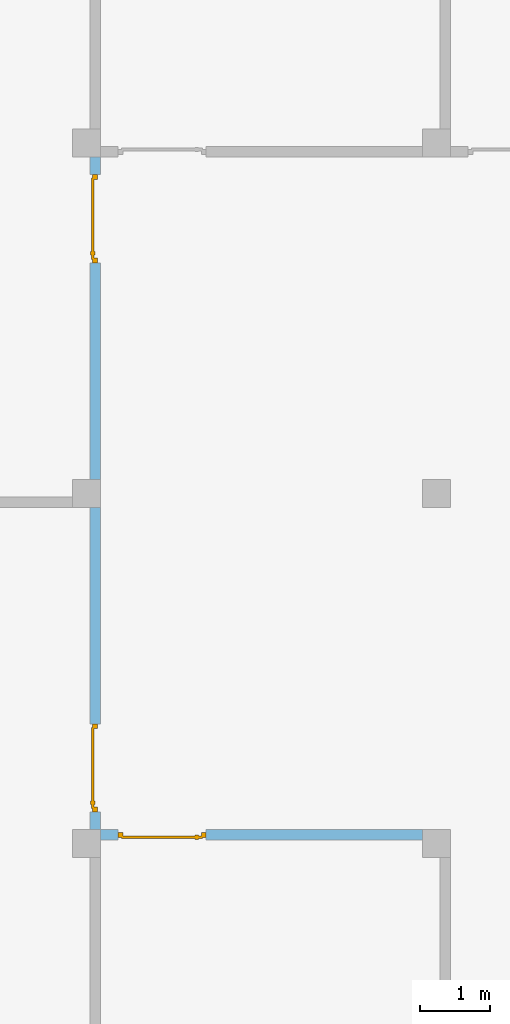
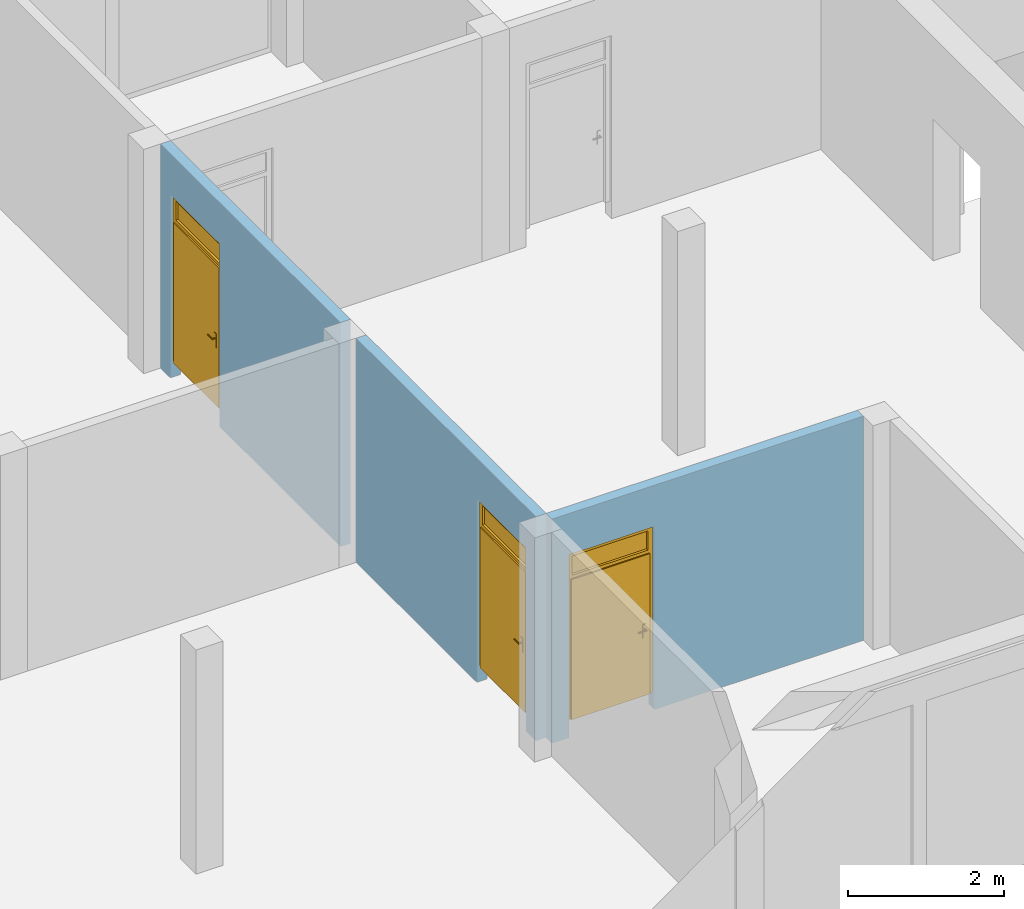
# One storey, part 2 of 6: 3 doors, 3 openings, plus 3 elements that do not belong to this part.
"""IFC2X3 building model written with IfcOpenShell, lengths in metres."""

from ifc_helpers import new_model, entity, si_unit, converted_unit, frame, frame_2d, origin, origin_with_axes, place, context, subcontext, project, spatial, polyline, rectangle, outline, extrude, closed_shell, open_shell, surface_model, source, transform, mapped, material, layer, layer_set, layer_usage, type_object, element, fill, save


model = new_model("IFC2X3")

# Units and contexts
model_context = context("Model", 3, precision=1e-05, world=origin())
body_context = subcontext(model_context, "Body", "Model", "MODEL_VIEW")
ifc_project = project(units=[si_unit("LENGTHUNIT", "METRE"), si_unit("AREAUNIT", "SQUARE_METRE"), si_unit("VOLUMEUNIT", "CUBIC_METRE"), si_unit("MASSUNIT", "GRAM", prefix="KILO"), converted_unit("PLANEANGLEUNIT", "DEGREE", entity("IfcPlaneAngleMeasure", 0.0174532925199433), si_unit("PLANEANGLEUNIT", "RADIAN"), dimensions=[0, 0, 0, 0, 0, 0, 0])], contexts=[model_context])

# Site, building, storey
site_placement = place(None, origin())
site = spatial("IfcSite", under=ifc_project, at=site_placement, CompositionType="ELEMENT")
building_placement = place(site_placement, origin())
building = spatial("IfcBuilding", under=site, at=building_placement, CompositionType="ELEMENT")
storey_placement = place(building_placement, frame((0.0, 0.0, 8.6)))
storey = spatial("IfcBuildingStorey", under=building, at=storey_placement, Name="2. Obergeschoss", CompositionType="ELEMENT", Elevation=8.6)

# Wall, opening, door
ifc_material_1 = material()
ifc_layer_1 = layer(ifc_material_1, 0.15)
ifc_layer_set_1 = layer_set([ifc_layer_1])
ifc_layer_usage_1 = layer_usage(ifc_layer_set_1, "AXIS2", "POSITIVE", -0.15)
wall_1_placement = place(storey_placement, frame((10.4, 5.25, 0.0)))
wall_1 = element("IfcWallStandardCase", 1, at=wall_1_placement, inside=storey, material=ifc_layer_usage_1, context=body_context, shape_type="SweptSolid", body=[
    extrude(rectangle(XDim=4.6, YDim=0.15, at=frame_2d((2.3, 0.075), x_axis=(1.0, 0.0))), origin_with_axes(), (0.0, 0.0, 1.0), 3.5),
])
opening_1_placement = place(wall_1_placement, frame((1.51, 0.15, 0.0), z_axis=(0.0, -1.0, 0.0), x_axis=(0.0, 0.0, 1.0)))
opening_1 = element("IfcOpeningElement", 2, at=opening_1_placement, cuts=wall_1, ObjectType="Opening", context=body_context, shape_type="SweptSolid", body=[
    extrude(outline(polyline([(0.0, 1.26), (2.86, 1.26), (2.86, 0.0), (0.0, 0.0), (0.0, 1.26)])), origin_with_axes(), (0.0, 0.0, 1.0), 0.15),
])
ifc_material_2 = material()
door_style_1 = type_object("IfcDoorStyle", ConstructionType="NOTDEFINED", OperationType="SINGLE_SWING_RIGHT", ParameterTakesPrecedence=False, Sizeable=False)
shared_shape_1 = source(origin_with_axes(), body_context, "Body", "SurfaceModel", [
    surface_model("IfcShellBasedSurfaceModel", [(0.0, 0.0700000000000009, 2.86), (0.0, 0.07, 0.25), (0.07, 0.07, 0.25), (0.07, 0.0700000000000009, 2.86), (0.0, 0.0, 0.25), (0.0, 0.0, 2.86), (0.07, 0.0, 2.86), (0.07, 0.0, 0.25)], [closed_shell([[[0, 1, 2, 3]], [[4, 5, 6, 7]], [[1, 0, 5, 4]], [[2, 1, 4, 7]], [[3, 2, 7, 6]], [[0, 3, 6, 5]]], orient=[[False], [False], [False], [False], [False], [False]])]),
    surface_model("IfcShellBasedSurfaceModel", [(1.19, 0.0700000000000009, 2.86), (1.19, 0.07, 0.25), (1.26, 0.07, 0.25), (1.26, 0.0700000000000009, 2.86), (1.19, 0.0, 0.25), (1.19, 0.0, 2.86), (1.26, 0.0, 2.86), (1.26, 0.0, 0.25)], [closed_shell([[[0, 1, 2, 3]], [[4, 5, 6, 7]], [[1, 0, 5, 4]], [[2, 1, 4, 7]], [[3, 2, 7, 6]], [[0, 3, 6, 5]]], orient=[[False], [False], [False], [False], [False], [False]])]),
    surface_model("IfcShellBasedSurfaceModel", [(0.07, 0.0700000000000009, 2.86), (0.07, 0.0700000000000009, 2.79), (1.19, 0.0700000000000009, 2.79), (1.19, 0.0700000000000009, 2.86), (0.07, 0.0, 2.79), (0.07, 0.0, 2.86), (1.19, 0.0, 2.86), (1.19, 0.0, 2.79)], [closed_shell([[[0, 1, 2, 3]], [[4, 5, 6, 7]], [[1, 0, 5, 4]], [[2, 1, 4, 7]], [[3, 2, 7, 6]], [[0, 3, 6, 5]]], orient=[[False], [False], [False], [False], [False], [False]])]),
    surface_model("IfcShellBasedSurfaceModel", [(0.07, 0.0700000000000009, 2.49), (0.07, 0.0700000000000009, 2.42), (1.19, 0.0700000000000009, 2.42), (1.19, 0.0700000000000009, 2.49), (0.07, 0.0, 2.42), (0.07, 0.0, 2.49), (1.19, 0.0, 2.49), (1.19, 0.0, 2.42)], [closed_shell([[[0, 1, 2, 3]], [[4, 5, 6, 7]], [[1, 0, 5, 4]], [[2, 1, 4, 7]], [[3, 2, 7, 6]], [[0, 3, 6, 5]]], orient=[[False], [False], [False], [False], [False], [False]])]),
    surface_model("IfcShellBasedSurfaceModel", [(0.05, 0.0900000000000009, 2.44), (0.05, 0.0900000000000009, 0.25), (1.21, 0.09, 0.25), (1.21, 0.0900000000000009, 2.44), (0.05, 0.05, 0.25), (0.05, 0.0500000000000009, 2.44), (1.21, 0.05, 2.44), (1.21, 0.05, 0.25)], [closed_shell([[[0, 1, 2, 3]], [[4, 5, 6, 7]], [[1, 0, 5, 4]], [[2, 1, 4, 7]], [[3, 2, 7, 6]], [[0, 3, 6, 5]]], orient=[[False], [False], [False], [False], [False], [False]])]),
    surface_model("IfcShellBasedSurfaceModel", [(0.11, 0.05, 1.375), (0.11, 0.05, 1.16), (0.16, 0.05, 1.16), (0.16, 0.05, 1.375), (0.11, 0.04, 1.16), (0.11, 0.04, 1.375), (0.16, 0.04, 1.375), (0.16, 0.04, 1.16)], [closed_shell([[[0, 1, 2, 3]], [[4, 5, 6, 7]], [[1, 0, 5, 4]], [[2, 1, 4, 7]], [[3, 2, 7, 6]], [[0, 3, 6, 5]]], orient=[[False], [False], [False], [False], [False], [False]])]),
    surface_model("IfcShellBasedSurfaceModel", [(0.135, 0.04, 1.31), (0.13, 0.04, 1.30866025403784), (0.126339745962156, 0.04, 1.305), (0.125, 0.04, 1.3), (0.126339745962156, 0.04, 1.295), (0.13, 0.04, 1.29133974596216), (0.135, 0.04, 1.29), (0.14, 0.04, 1.29133974596216), (0.143660254037844, 0.04, 1.295), (0.145, 0.04, 1.3), (0.143660254037844, 0.04, 1.305), (0.14, 0.04, 1.30866025403784), (0.135, 0.0, 1.31), (0.13, -0.005, 1.30866025403784), (0.126339745962156, -0.00866025403784442, 1.305), (0.125, -0.01, 1.3), (0.126339745962156, -0.00866025403784442, 1.295), (0.13, -0.005, 1.29133974596216), (0.135, 0.0, 1.29), (0.14, 0.005, 1.29133974596216), (0.143660254037844, 0.00866025403784442, 1.295), (0.145, 0.01, 1.3), (0.143660254037844, 0.00866025403784442, 1.305), (0.14, 0.005, 1.30866025403784), (0.25, 0.0, 1.31), (0.25, 0.005, 1.30866025403784), (0.25, 0.00866025403784442, 1.305), (0.25, 0.01, 1.3), (0.25, 0.00866025403784442, 1.295), (0.25, 0.005, 1.29133974596216), (0.25, 0.0, 1.29), (0.25, -0.005, 1.29133974596216), (0.25, -0.00866025403784442, 1.295), (0.25, -0.01, 1.3), (0.25, -0.00866025403784442, 1.305), (0.25, -0.005, 1.30866025403784)], [closed_shell([[[0, 1, 2, 3, 4, 5, 6, 7, 8, 9, 10, 11]], [[0, 12, 13, 1]], [[1, 13, 14, 2]], [[2, 14, 15, 3]], [[3, 15, 16, 4]], [[4, 16, 17, 5]], [[5, 17, 18, 6]], [[6, 18, 19, 7]], [[7, 19, 20, 8]], [[8, 20, 21, 9]], [[9, 21, 22, 10]], [[10, 22, 23, 11]], [[11, 23, 12, 0]], [[24, 25, 26, 27, 28, 29, 30, 31, 32, 33, 34, 35]], [[12, 24, 35, 13]], [[13, 35, 34, 14]], [[14, 34, 33, 15]], [[15, 33, 32, 16]], [[16, 32, 31, 17]], [[17, 31, 30, 18]], [[18, 30, 29, 19]], [[19, 29, 28, 20]], [[20, 28, 27, 21]], [[21, 27, 26, 22]], [[22, 26, 25, 23]], [[23, 25, 24, 12]]], orient=[[False], [False], [False], [False], [False], [False], [False], [False], [False], [False], [False], [False], [False], [False], [False], [False], [False], [False], [False], [False], [False], [False], [False], [False], [False], [False]])]),
    surface_model("IfcShellBasedSurfaceModel", [(0.11, 0.0900000000000009, 1.375), (0.16, 0.0900000000000009, 1.375), (0.16, 0.0900000000000009, 1.16), (0.11, 0.0900000000000009, 1.16), (0.11, 0.100000000000001, 1.16), (0.16, 0.100000000000001, 1.16), (0.16, 0.100000000000001, 1.375), (0.11, 0.100000000000001, 1.375)], [closed_shell([[[0, 1, 2, 3]], [[4, 5, 6, 7]], [[3, 4, 7, 0]], [[2, 5, 4, 3]], [[1, 6, 5, 2]], [[0, 7, 6, 1]]], orient=[[False], [False], [False], [False], [False], [False]])]),
    surface_model("IfcShellBasedSurfaceModel", [(0.135, 0.100000000000001, 1.31), (0.14, 0.100000000000001, 1.30866025403784), (0.143660254037844, 0.100000000000001, 1.305), (0.145, 0.100000000000001, 1.3), (0.143660254037844, 0.100000000000001, 1.295), (0.14, 0.100000000000001, 1.29133974596216), (0.135, 0.100000000000001, 1.29), (0.13, 0.100000000000001, 1.29133974596216), (0.126339745962156, 0.100000000000001, 1.295), (0.125, 0.100000000000001, 1.3), (0.126339745962156, 0.100000000000001, 1.305), (0.13, 0.100000000000001, 1.30866025403784), (0.13, 0.145000000000001, 1.30866025403784), (0.135, 0.140000000000001, 1.31), (0.126339745962156, 0.148660254037845, 1.305), (0.125, 0.150000000000001, 1.3), (0.126339745962156, 0.148660254037845, 1.295), (0.13, 0.145000000000001, 1.29133974596216), (0.135, 0.140000000000001, 1.29), (0.14, 0.135000000000001, 1.29133974596216), (0.143660254037844, 0.131339745962157, 1.295), (0.145, 0.130000000000001, 1.3), (0.143660254037844, 0.131339745962157, 1.305), (0.14, 0.135000000000001, 1.30866025403784), (0.25, 0.140000000000001, 1.31), (0.25, 0.145000000000001, 1.30866025403784), (0.25, 0.148660254037845, 1.305), (0.25, 0.150000000000001, 1.3), (0.25, 0.148660254037845, 1.295), (0.25, 0.145000000000001, 1.29133974596216), (0.25, 0.140000000000001, 1.29), (0.25, 0.135000000000001, 1.29133974596216), (0.25, 0.131339745962157, 1.295), (0.25, 0.130000000000001, 1.3), (0.25, 0.131339745962157, 1.305), (0.25, 0.135000000000001, 1.30866025403784)], [closed_shell([[[0, 1, 2, 3, 4, 5, 6, 7, 8, 9, 10, 11]], [[0, 11, 12, 13]], [[11, 10, 14, 12]], [[10, 9, 15, 14]], [[9, 8, 16, 15]], [[8, 7, 17, 16]], [[7, 6, 18, 17]], [[6, 5, 19, 18]], [[5, 4, 20, 19]], [[4, 3, 21, 20]], [[3, 2, 22, 21]], [[2, 1, 23, 22]], [[1, 0, 13, 23]], [[24, 25, 26, 27, 28, 29, 30, 31, 32, 33, 34, 35]], [[13, 12, 25, 24]], [[12, 14, 26, 25]], [[14, 15, 27, 26]], [[15, 16, 28, 27]], [[16, 17, 29, 28]], [[17, 18, 30, 29]], [[18, 19, 31, 30]], [[19, 20, 32, 31]], [[20, 21, 33, 32]], [[21, 22, 34, 33]], [[22, 23, 35, 34]], [[23, 13, 24, 35]]], orient=[[False], [False], [False], [False], [False], [False], [False], [False], [False], [False], [False], [False], [False], [False], [False], [False], [False], [False], [False], [False], [False], [False], [False], [False], [False], [False]])]),
    surface_model("IfcShellBasedSurfaceModel", [(0.07, 0.0350000000000009, 2.49), (1.19, 0.035, 2.49), (1.19, 0.035, 2.79), (0.07, 0.0350000000000009, 2.79)], [open_shell([[[0, 1, 2, 3]]], orient=[[False]])]),
])
door_1_placement = place(opening_1_placement, frame((0.0, 0.0, 0.04), z_axis=(1.0, 0.0, 0.0), x_axis=(0.0, 1.0, 0.0)))
door_1 = element("IfcDoor", 3, at=door_1_placement, inside=storey, type_object=door_style_1, material=ifc_material_2, OverallHeight=2.86, OverallWidth=1.26, context=body_context, shape_type="MappedRepresentation", body=[
    mapped(shared_shape_1, transform((0.0, 0.0, 0.0), x_axis=(1.0, 0.0, 0.0), y_axis=(0.0, 1.0, 0.0), z_axis=(0.0, 0.0, 1.0), scale=1.0)),
])
fill(opening_1, door_1)

ifc_material_3 = material()
ifc_layer_2 = layer(ifc_material_3, 0.15)
ifc_layer_set_2 = layer_set([ifc_layer_2])
ifc_layer_usage_2 = layer_usage(ifc_layer_set_2, "AXIS2", "POSITIVE", -0.15)
wall_2_placement = place(storey_placement, frame((10.25, 10.0, 0.0), z_axis=(0.0, 0.0, 1.0), x_axis=(0.0, -1.0, 0.0)))
wall_2 = element("IfcWallStandardCase", 4, at=wall_2_placement, inside=storey, material=ifc_layer_usage_2, context=body_context, shape_type="SweptSolid", body=[
    extrude(rectangle(XDim=4.6, YDim=0.15, at=frame_2d((2.3, 0.075), x_axis=(1.0, 0.0))), origin_with_axes(), (0.0, 0.0, 1.0), 3.5),
])
opening_2_placement = place(wall_2_placement, frame((4.35, 0.15, 0.0), z_axis=(0.0, -1.0, 0.0), x_axis=(0.0, 0.0, 1.0)))
opening_2 = element("IfcOpeningElement", 5, at=opening_2_placement, cuts=wall_2, ObjectType="Opening", context=body_context, shape_type="SweptSolid", body=[
    extrude(outline(polyline([(0.0, 1.26), (2.86, 1.26), (2.86, 0.0), (0.0, 0.0), (0.0, 1.26)])), origin_with_axes(), (0.0, 0.0, 1.0), 0.15),
])
ifc_material_4 = material()
door_style_2 = type_object("IfcDoorStyle", ConstructionType="NOTDEFINED", OperationType="SINGLE_SWING_RIGHT", ParameterTakesPrecedence=False, Sizeable=False)
shared_shape_2 = source(origin_with_axes(), body_context, "Body", "SurfaceModel", [
    surface_model("IfcShellBasedSurfaceModel", [(0.0, 0.07, 2.86), (0.0, 0.07, 0.25), (0.07, 0.07, 0.25), (0.07, 0.07, 2.86), (0.0, 0.0, 0.25), (0.0, 0.0, 2.86), (0.07, 0.0, 2.86), (0.07, 0.0, 0.25)], [closed_shell([[[0, 1, 2, 3]], [[4, 5, 6, 7]], [[1, 0, 5, 4]], [[2, 1, 4, 7]], [[3, 2, 7, 6]], [[0, 3, 6, 5]]], orient=[[False], [False], [False], [False], [False], [False]])]),
    surface_model("IfcShellBasedSurfaceModel", [(1.19, 0.07, 2.86), (1.19, 0.07, 0.25), (1.26, 0.07, 0.25), (1.26, 0.07, 2.86), (1.19, 0.0, 0.25), (1.19, 0.0, 2.86), (1.26, 0.0, 2.86), (1.26, 0.0, 0.25)], [closed_shell([[[0, 1, 2, 3]], [[4, 5, 6, 7]], [[1, 0, 5, 4]], [[2, 1, 4, 7]], [[3, 2, 7, 6]], [[0, 3, 6, 5]]], orient=[[False], [False], [False], [False], [False], [False]])]),
    surface_model("IfcShellBasedSurfaceModel", [(0.07, 0.07, 2.86), (0.07, 0.07, 2.79), (1.19, 0.07, 2.79), (1.19, 0.07, 2.86), (0.07, 0.0, 2.79), (0.07, 0.0, 2.86), (1.19, 0.0, 2.86), (1.19, 0.0, 2.79)], [closed_shell([[[0, 1, 2, 3]], [[4, 5, 6, 7]], [[1, 0, 5, 4]], [[2, 1, 4, 7]], [[3, 2, 7, 6]], [[0, 3, 6, 5]]], orient=[[False], [False], [False], [False], [False], [False]])]),
    surface_model("IfcShellBasedSurfaceModel", [(0.07, 0.07, 2.49), (0.07, 0.07, 2.42), (1.19, 0.07, 2.42), (1.19, 0.07, 2.49), (0.07, 0.0, 2.42), (0.07, 0.0, 2.49), (1.19, 0.0, 2.49), (1.19, 0.0, 2.42)], [closed_shell([[[0, 1, 2, 3]], [[4, 5, 6, 7]], [[1, 0, 5, 4]], [[2, 1, 4, 7]], [[3, 2, 7, 6]], [[0, 3, 6, 5]]], orient=[[False], [False], [False], [False], [False], [False]])]),
    surface_model("IfcShellBasedSurfaceModel", [(0.05, 0.09, 2.44), (0.05, 0.09, 0.25), (1.21, 0.09, 0.25), (1.21, 0.09, 2.44), (0.05, 0.05, 0.25), (0.05, 0.05, 2.44), (1.21, 0.05, 2.44), (1.21, 0.05, 0.25)], [closed_shell([[[0, 1, 2, 3]], [[4, 5, 6, 7]], [[1, 0, 5, 4]], [[2, 1, 4, 7]], [[3, 2, 7, 6]], [[0, 3, 6, 5]]], orient=[[False], [False], [False], [False], [False], [False]])]),
    surface_model("IfcShellBasedSurfaceModel", [(0.11, 0.05, 1.375), (0.11, 0.05, 1.16), (0.16, 0.05, 1.16), (0.16, 0.05, 1.375), (0.11, 0.04, 1.16), (0.11, 0.04, 1.375), (0.16, 0.04, 1.375), (0.16, 0.04, 1.16)], [closed_shell([[[0, 1, 2, 3]], [[4, 5, 6, 7]], [[1, 0, 5, 4]], [[2, 1, 4, 7]], [[3, 2, 7, 6]], [[0, 3, 6, 5]]], orient=[[False], [False], [False], [False], [False], [False]])]),
    surface_model("IfcShellBasedSurfaceModel", [(0.135, 0.04, 1.31), (0.13, 0.04, 1.30866025403784), (0.126339745962156, 0.04, 1.305), (0.125, 0.04, 1.3), (0.126339745962156, 0.04, 1.295), (0.13, 0.04, 1.29133974596216), (0.135, 0.04, 1.29), (0.14, 0.04, 1.29133974596216), (0.143660254037844, 0.04, 1.295), (0.145, 0.04, 1.3), (0.143660254037844, 0.04, 1.305), (0.14, 0.04, 1.30866025403784), (0.135, 0.0, 1.31), (0.13, -0.005, 1.30866025403784), (0.126339745962156, -0.00866025403784442, 1.305), (0.125, -0.01, 1.3), (0.126339745962156, -0.00866025403784442, 1.295), (0.13, -0.005, 1.29133974596216), (0.135, 0.0, 1.29), (0.14, 0.005, 1.29133974596216), (0.143660254037844, 0.00866025403784442, 1.295), (0.145, 0.01, 1.3), (0.143660254037844, 0.00866025403784442, 1.305), (0.14, 0.005, 1.30866025403784), (0.25, 0.0, 1.31), (0.25, 0.005, 1.30866025403784), (0.25, 0.00866025403784442, 1.305), (0.25, 0.01, 1.3), (0.25, 0.00866025403784442, 1.295), (0.25, 0.005, 1.29133974596216), (0.25, 0.0, 1.29), (0.25, -0.005, 1.29133974596216), (0.25, -0.00866025403784442, 1.295), (0.25, -0.01, 1.3), (0.25, -0.00866025403784442, 1.305), (0.25, -0.005, 1.30866025403784)], [closed_shell([[[0, 1, 2, 3, 4, 5, 6, 7, 8, 9, 10, 11]], [[0, 12, 13, 1]], [[1, 13, 14, 2]], [[2, 14, 15, 3]], [[3, 15, 16, 4]], [[4, 16, 17, 5]], [[5, 17, 18, 6]], [[6, 18, 19, 7]], [[7, 19, 20, 8]], [[8, 20, 21, 9]], [[9, 21, 22, 10]], [[10, 22, 23, 11]], [[11, 23, 12, 0]], [[24, 25, 26, 27, 28, 29, 30, 31, 32, 33, 34, 35]], [[12, 24, 35, 13]], [[13, 35, 34, 14]], [[14, 34, 33, 15]], [[15, 33, 32, 16]], [[16, 32, 31, 17]], [[17, 31, 30, 18]], [[18, 30, 29, 19]], [[19, 29, 28, 20]], [[20, 28, 27, 21]], [[21, 27, 26, 22]], [[22, 26, 25, 23]], [[23, 25, 24, 12]]], orient=[[False], [False], [False], [False], [False], [False], [False], [False], [False], [False], [False], [False], [False], [False], [False], [False], [False], [False], [False], [False], [False], [False], [False], [False], [False], [False]])]),
    surface_model("IfcShellBasedSurfaceModel", [(0.11, 0.09, 1.375), (0.16, 0.09, 1.375), (0.16, 0.09, 1.16), (0.11, 0.09, 1.16), (0.11, 0.1, 1.16), (0.16, 0.1, 1.16), (0.16, 0.1, 1.375), (0.11, 0.1, 1.375)], [closed_shell([[[0, 1, 2, 3]], [[4, 5, 6, 7]], [[3, 4, 7, 0]], [[2, 5, 4, 3]], [[1, 6, 5, 2]], [[0, 7, 6, 1]]], orient=[[False], [False], [False], [False], [False], [False]])]),
    surface_model("IfcShellBasedSurfaceModel", [(0.135, 0.1, 1.31), (0.14, 0.1, 1.30866025403784), (0.143660254037844, 0.1, 1.305), (0.145, 0.1, 1.3), (0.143660254037844, 0.1, 1.295), (0.14, 0.1, 1.29133974596216), (0.135, 0.1, 1.29), (0.13, 0.1, 1.29133974596216), (0.126339745962156, 0.1, 1.295), (0.125, 0.1, 1.3), (0.126339745962156, 0.1, 1.305), (0.13, 0.1, 1.30866025403784), (0.13, 0.145, 1.30866025403784), (0.135, 0.14, 1.31), (0.126339745962156, 0.148660254037844, 1.305), (0.125, 0.15, 1.3), (0.126339745962156, 0.148660254037844, 1.295), (0.13, 0.145, 1.29133974596216), (0.135, 0.14, 1.29), (0.14, 0.135, 1.29133974596216), (0.143660254037844, 0.131339745962156, 1.295), (0.145, 0.13, 1.3), (0.143660254037844, 0.131339745962156, 1.305), (0.14, 0.135, 1.30866025403784), (0.25, 0.14, 1.31), (0.25, 0.145, 1.30866025403784), (0.25, 0.148660254037844, 1.305), (0.25, 0.15, 1.3), (0.25, 0.148660254037844, 1.295), (0.25, 0.145, 1.29133974596216), (0.25, 0.14, 1.29), (0.25, 0.135, 1.29133974596216), (0.25, 0.131339745962156, 1.295), (0.25, 0.13, 1.3), (0.25, 0.131339745962156, 1.305), (0.25, 0.135, 1.30866025403784)], [closed_shell([[[0, 1, 2, 3, 4, 5, 6, 7, 8, 9, 10, 11]], [[0, 11, 12, 13]], [[11, 10, 14, 12]], [[10, 9, 15, 14]], [[9, 8, 16, 15]], [[8, 7, 17, 16]], [[7, 6, 18, 17]], [[6, 5, 19, 18]], [[5, 4, 20, 19]], [[4, 3, 21, 20]], [[3, 2, 22, 21]], [[2, 1, 23, 22]], [[1, 0, 13, 23]], [[24, 25, 26, 27, 28, 29, 30, 31, 32, 33, 34, 35]], [[13, 12, 25, 24]], [[12, 14, 26, 25]], [[14, 15, 27, 26]], [[15, 16, 28, 27]], [[16, 17, 29, 28]], [[17, 18, 30, 29]], [[18, 19, 31, 30]], [[19, 20, 32, 31]], [[20, 21, 33, 32]], [[21, 22, 34, 33]], [[22, 23, 35, 34]], [[23, 13, 24, 35]]], orient=[[False], [False], [False], [False], [False], [False], [False], [False], [False], [False], [False], [False], [False], [False], [False], [False], [False], [False], [False], [False], [False], [False], [False], [False], [False], [False]])]),
    surface_model("IfcShellBasedSurfaceModel", [(0.07, 0.035, 2.49), (1.19, 0.035, 2.49), (1.19, 0.035, 2.79), (0.07, 0.035, 2.79)], [open_shell([[[0, 1, 2, 3]]], orient=[[False]])]),
])
door_2_placement = place(opening_2_placement, frame((0.0, 0.0, 0.04), z_axis=(1.0, 0.0, 0.0), x_axis=(0.0, 1.0, 0.0)))
door_2 = element("IfcDoor", 6, at=door_2_placement, inside=storey, type_object=door_style_2, material=ifc_material_4, OverallHeight=2.86, OverallWidth=1.26, context=body_context, shape_type="MappedRepresentation", body=[
    mapped(shared_shape_2, transform((0.0, 0.0, 0.0), x_axis=(1.0, 0.0, 0.0), y_axis=(0.0, 1.0, 0.0), z_axis=(0.0, 0.0, 1.0), scale=1.0)),
])
fill(opening_2, door_2)

ifc_material_5 = material()
ifc_layer_3 = layer(ifc_material_5, 0.15)
ifc_layer_set_3 = layer_set([ifc_layer_3])
ifc_layer_usage_3 = layer_usage(ifc_layer_set_3, "AXIS2", "POSITIVE", -0.15)
wall_3_placement = place(storey_placement, frame((10.25, 15.0, 0.0), z_axis=(0.0, 0.0, 1.0), x_axis=(0.0, -1.0, 0.0)))
wall_3 = element("IfcWallStandardCase", 7, at=wall_3_placement, inside=storey, material=ifc_layer_usage_3, context=body_context, shape_type="SweptSolid", body=[
    extrude(rectangle(XDim=4.6, YDim=0.15, at=frame_2d((2.3, 0.075), x_axis=(1.0, 0.0))), origin_with_axes(), (0.0, 0.0, 1.0), 3.5),
])
opening_3_placement = place(wall_3_placement, frame((1.51, 0.15, 0.0), z_axis=(0.0, -1.0, 0.0), x_axis=(0.0, 0.0, 1.0)))
opening_3 = element("IfcOpeningElement", 8, at=opening_3_placement, cuts=wall_3, ObjectType="Opening", context=body_context, shape_type="SweptSolid", body=[
    extrude(outline(polyline([(0.0, 1.26), (2.86, 1.26), (2.86, 0.0), (0.0, 0.0), (0.0, 1.26)])), origin_with_axes(), (0.0, 0.0, 1.0), 0.15),
])
ifc_material_6 = material()
door_style_3 = type_object("IfcDoorStyle", ConstructionType="NOTDEFINED", OperationType="SINGLE_SWING_RIGHT", ParameterTakesPrecedence=False, Sizeable=False)
shared_shape_3 = source(origin_with_axes(), body_context, "Body", "SurfaceModel", [
    surface_model("IfcShellBasedSurfaceModel", [(0.0, 0.07, 2.86), (0.0, 0.07, 0.25), (0.07, 0.07, 0.25), (0.07, 0.07, 2.86), (0.0, 0.0, 0.25), (0.0, 0.0, 2.86), (0.07, 0.0, 2.86), (0.07, 0.0, 0.25)], [closed_shell([[[0, 1, 2, 3]], [[4, 5, 6, 7]], [[1, 0, 5, 4]], [[2, 1, 4, 7]], [[3, 2, 7, 6]], [[0, 3, 6, 5]]], orient=[[False], [False], [False], [False], [False], [False]])]),
    surface_model("IfcShellBasedSurfaceModel", [(1.19, 0.07, 2.86), (1.19, 0.07, 0.25), (1.26, 0.07, 0.25), (1.26, 0.07, 2.86), (1.19, 0.0, 0.25), (1.19, 0.0, 2.86), (1.26, 0.0, 2.86), (1.26, 0.0, 0.25)], [closed_shell([[[0, 1, 2, 3]], [[4, 5, 6, 7]], [[1, 0, 5, 4]], [[2, 1, 4, 7]], [[3, 2, 7, 6]], [[0, 3, 6, 5]]], orient=[[False], [False], [False], [False], [False], [False]])]),
    surface_model("IfcShellBasedSurfaceModel", [(0.07, 0.07, 2.86), (0.07, 0.07, 2.79), (1.19, 0.07, 2.79), (1.19, 0.07, 2.86), (0.07, 0.0, 2.79), (0.07, 0.0, 2.86), (1.19, 0.0, 2.86), (1.19, 0.0, 2.79)], [closed_shell([[[0, 1, 2, 3]], [[4, 5, 6, 7]], [[1, 0, 5, 4]], [[2, 1, 4, 7]], [[3, 2, 7, 6]], [[0, 3, 6, 5]]], orient=[[False], [False], [False], [False], [False], [False]])]),
    surface_model("IfcShellBasedSurfaceModel", [(0.07, 0.07, 2.49), (0.07, 0.07, 2.42), (1.19, 0.07, 2.42), (1.19, 0.07, 2.49), (0.07, 0.0, 2.42), (0.07, 0.0, 2.49), (1.19, 0.0, 2.49), (1.19, 0.0, 2.42)], [closed_shell([[[0, 1, 2, 3]], [[4, 5, 6, 7]], [[1, 0, 5, 4]], [[2, 1, 4, 7]], [[3, 2, 7, 6]], [[0, 3, 6, 5]]], orient=[[False], [False], [False], [False], [False], [False]])]),
    surface_model("IfcShellBasedSurfaceModel", [(0.05, 0.09, 2.44), (0.05, 0.09, 0.25), (1.21, 0.09, 0.25), (1.21, 0.09, 2.44), (0.05, 0.05, 0.25), (0.05, 0.05, 2.44), (1.21, 0.05, 2.44), (1.21, 0.05, 0.25)], [closed_shell([[[0, 1, 2, 3]], [[4, 5, 6, 7]], [[1, 0, 5, 4]], [[2, 1, 4, 7]], [[3, 2, 7, 6]], [[0, 3, 6, 5]]], orient=[[False], [False], [False], [False], [False], [False]])]),
    surface_model("IfcShellBasedSurfaceModel", [(0.11, 0.05, 1.375), (0.11, 0.05, 1.16), (0.16, 0.05, 1.16), (0.16, 0.05, 1.375), (0.11, 0.04, 1.16), (0.11, 0.04, 1.375), (0.16, 0.04, 1.375), (0.16, 0.04, 1.16)], [closed_shell([[[0, 1, 2, 3]], [[4, 5, 6, 7]], [[1, 0, 5, 4]], [[2, 1, 4, 7]], [[3, 2, 7, 6]], [[0, 3, 6, 5]]], orient=[[False], [False], [False], [False], [False], [False]])]),
    surface_model("IfcShellBasedSurfaceModel", [(0.135, 0.04, 1.31), (0.13, 0.04, 1.30866025403784), (0.126339745962156, 0.04, 1.305), (0.125, 0.04, 1.3), (0.126339745962156, 0.04, 1.295), (0.13, 0.04, 1.29133974596216), (0.135, 0.04, 1.29), (0.14, 0.04, 1.29133974596216), (0.143660254037844, 0.04, 1.295), (0.145, 0.04, 1.3), (0.143660254037844, 0.04, 1.305), (0.14, 0.04, 1.30866025403784), (0.135, 0.0, 1.31), (0.13, -0.005, 1.30866025403784), (0.126339745962156, -0.00866025403784442, 1.305), (0.125, -0.01, 1.3), (0.126339745962156, -0.00866025403784442, 1.295), (0.13, -0.005, 1.29133974596216), (0.135, 0.0, 1.29), (0.14, 0.005, 1.29133974596216), (0.143660254037844, 0.00866025403784442, 1.295), (0.145, 0.01, 1.3), (0.143660254037844, 0.00866025403784442, 1.305), (0.14, 0.005, 1.30866025403784), (0.25, 0.0, 1.31), (0.25, 0.005, 1.30866025403784), (0.25, 0.00866025403784442, 1.305), (0.25, 0.01, 1.3), (0.25, 0.00866025403784442, 1.295), (0.25, 0.005, 1.29133974596216), (0.25, 0.0, 1.29), (0.25, -0.005, 1.29133974596216), (0.25, -0.00866025403784442, 1.295), (0.25, -0.01, 1.3), (0.25, -0.00866025403784442, 1.305), (0.25, -0.005, 1.30866025403784)], [closed_shell([[[0, 1, 2, 3, 4, 5, 6, 7, 8, 9, 10, 11]], [[0, 12, 13, 1]], [[1, 13, 14, 2]], [[2, 14, 15, 3]], [[3, 15, 16, 4]], [[4, 16, 17, 5]], [[5, 17, 18, 6]], [[6, 18, 19, 7]], [[7, 19, 20, 8]], [[8, 20, 21, 9]], [[9, 21, 22, 10]], [[10, 22, 23, 11]], [[11, 23, 12, 0]], [[24, 25, 26, 27, 28, 29, 30, 31, 32, 33, 34, 35]], [[12, 24, 35, 13]], [[13, 35, 34, 14]], [[14, 34, 33, 15]], [[15, 33, 32, 16]], [[16, 32, 31, 17]], [[17, 31, 30, 18]], [[18, 30, 29, 19]], [[19, 29, 28, 20]], [[20, 28, 27, 21]], [[21, 27, 26, 22]], [[22, 26, 25, 23]], [[23, 25, 24, 12]]], orient=[[False], [False], [False], [False], [False], [False], [False], [False], [False], [False], [False], [False], [False], [False], [False], [False], [False], [False], [False], [False], [False], [False], [False], [False], [False], [False]])]),
    surface_model("IfcShellBasedSurfaceModel", [(0.11, 0.09, 1.375), (0.16, 0.09, 1.375), (0.16, 0.09, 1.16), (0.11, 0.09, 1.16), (0.11, 0.1, 1.16), (0.16, 0.1, 1.16), (0.16, 0.1, 1.375), (0.11, 0.1, 1.375)], [closed_shell([[[0, 1, 2, 3]], [[4, 5, 6, 7]], [[3, 4, 7, 0]], [[2, 5, 4, 3]], [[1, 6, 5, 2]], [[0, 7, 6, 1]]], orient=[[False], [False], [False], [False], [False], [False]])]),
    surface_model("IfcShellBasedSurfaceModel", [(0.135, 0.1, 1.31), (0.14, 0.1, 1.30866025403784), (0.143660254037844, 0.1, 1.305), (0.145, 0.1, 1.3), (0.143660254037844, 0.1, 1.295), (0.14, 0.1, 1.29133974596216), (0.135, 0.1, 1.29), (0.13, 0.1, 1.29133974596216), (0.126339745962156, 0.1, 1.295), (0.125, 0.1, 1.3), (0.126339745962156, 0.1, 1.305), (0.13, 0.1, 1.30866025403784), (0.13, 0.145, 1.30866025403784), (0.135, 0.14, 1.31), (0.126339745962156, 0.148660254037844, 1.305), (0.125, 0.15, 1.3), (0.126339745962156, 0.148660254037844, 1.295), (0.13, 0.145, 1.29133974596216), (0.135, 0.14, 1.29), (0.14, 0.135, 1.29133974596216), (0.143660254037844, 0.131339745962156, 1.295), (0.145, 0.13, 1.3), (0.143660254037844, 0.131339745962156, 1.305), (0.14, 0.135, 1.30866025403784), (0.25, 0.14, 1.31), (0.25, 0.145, 1.30866025403784), (0.25, 0.148660254037844, 1.305), (0.25, 0.15, 1.3), (0.25, 0.148660254037844, 1.295), (0.25, 0.145, 1.29133974596216), (0.25, 0.14, 1.29), (0.25, 0.135, 1.29133974596216), (0.25, 0.131339745962156, 1.295), (0.25, 0.13, 1.3), (0.25, 0.131339745962156, 1.305), (0.25, 0.135, 1.30866025403784)], [closed_shell([[[0, 1, 2, 3, 4, 5, 6, 7, 8, 9, 10, 11]], [[0, 11, 12, 13]], [[11, 10, 14, 12]], [[10, 9, 15, 14]], [[9, 8, 16, 15]], [[8, 7, 17, 16]], [[7, 6, 18, 17]], [[6, 5, 19, 18]], [[5, 4, 20, 19]], [[4, 3, 21, 20]], [[3, 2, 22, 21]], [[2, 1, 23, 22]], [[1, 0, 13, 23]], [[24, 25, 26, 27, 28, 29, 30, 31, 32, 33, 34, 35]], [[13, 12, 25, 24]], [[12, 14, 26, 25]], [[14, 15, 27, 26]], [[15, 16, 28, 27]], [[16, 17, 29, 28]], [[17, 18, 30, 29]], [[18, 19, 31, 30]], [[19, 20, 32, 31]], [[20, 21, 33, 32]], [[21, 22, 34, 33]], [[22, 23, 35, 34]], [[23, 13, 24, 35]]], orient=[[False], [False], [False], [False], [False], [False], [False], [False], [False], [False], [False], [False], [False], [False], [False], [False], [False], [False], [False], [False], [False], [False], [False], [False], [False], [False]])]),
    surface_model("IfcShellBasedSurfaceModel", [(0.07, 0.035, 2.49), (1.19, 0.035, 2.49), (1.19, 0.035, 2.79), (0.07, 0.035, 2.79)], [open_shell([[[0, 1, 2, 3]]], orient=[[False]])]),
])
door_3_placement = place(opening_3_placement, frame((0.0, 0.0, 0.04), z_axis=(1.0, 0.0, 0.0), x_axis=(0.0, 1.0, 0.0)))
door_3 = element("IfcDoor", 9, at=door_3_placement, inside=storey, type_object=door_style_3, material=ifc_material_6, OverallHeight=2.86, OverallWidth=1.26, context=body_context, shape_type="MappedRepresentation", body=[
    mapped(shared_shape_3, transform((0.0, 0.0, 0.0), x_axis=(1.0, 0.0, 0.0), y_axis=(0.0, 1.0, 0.0), z_axis=(0.0, 0.0, 1.0), scale=1.0)),
])
fill(opening_3, door_3)

save(model, "model.ifc")
